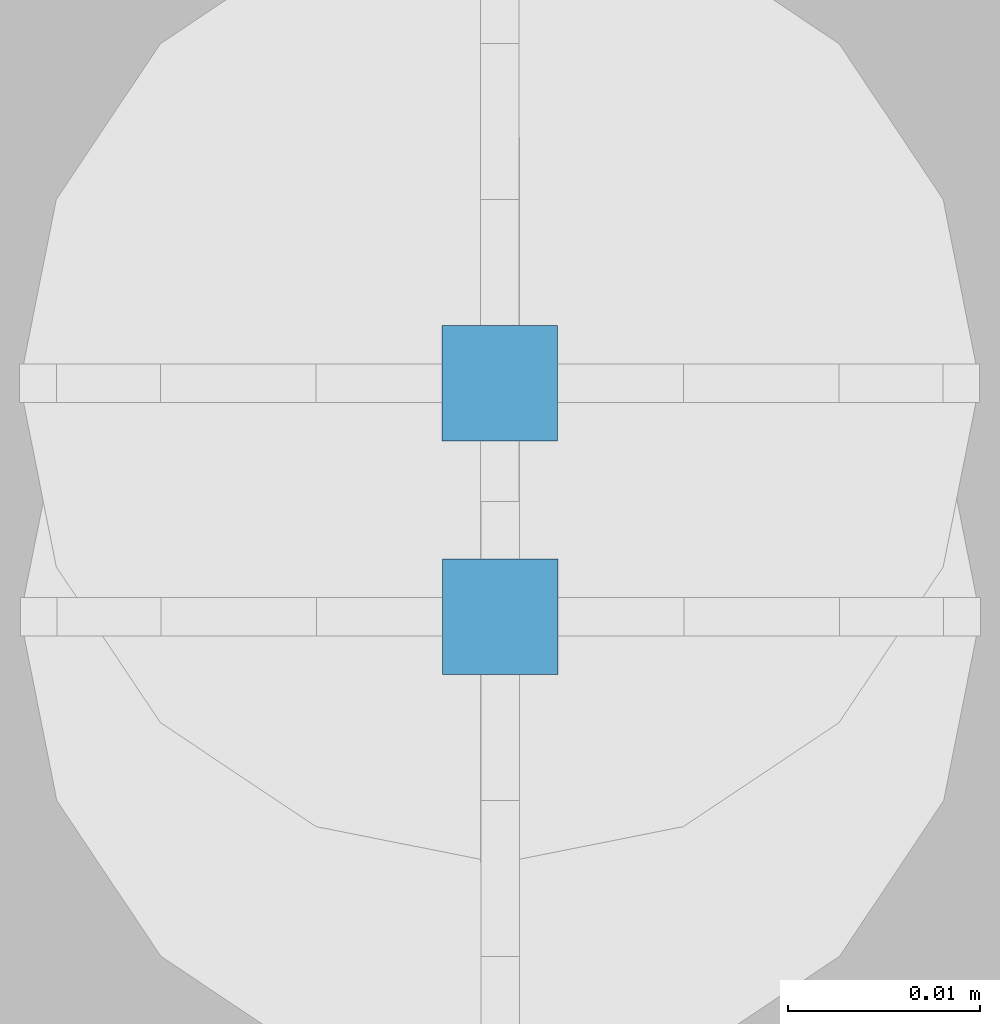
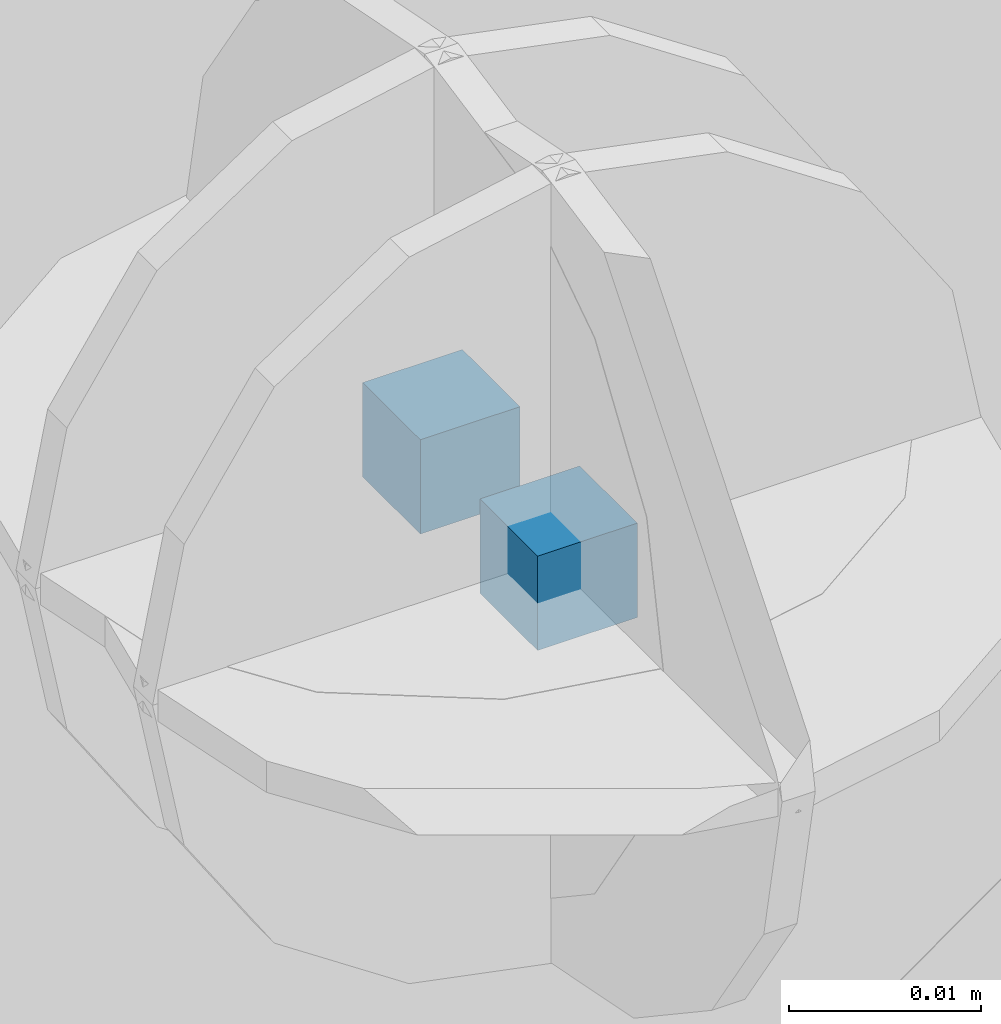
# One storey, part 69 of 325: 2 columns, 3 elements without a shape of their own.
"""IFC2X3 building model written with IfcOpenShell, lengths in millimetres."""

import ifcopenshell
import ifcopenshell.guid

model = None  # the IFC model being written
_history = None  # IfcOwnerHistory: only IFC2X3 demands one
_inside = {}  # id of a spatial element -> (the spatial element, [elements in it])
_under = {}  # id of a project, library or spatial element -> (it, [spatial elements below it])
_declared = {}  # id of a project -> (the project, [libraries it declares])
_typed = {}  # id of a type object -> (the type object, [elements of that type])
_made_of = {}  # id of a material, layer set ... -> (it, [elements and type objects made of it])


def new_model(schema):
    """Start an empty IFC model of exactly this schema.

    Asked for "IFC4X3", IfcOpenShell would pick the latest addendum, in which some entities
    have other attributes; the version numbers below select the first issue.
    IFC2X3 requires an IfcOwnerHistory on every rooted entity: one is made here for all.
    """
    global model, _history
    if schema == "IFC4X3":
        model = ifcopenshell.file(schema_version=(4, 3, 0, 0))
    else:
        model = ifcopenshell.file(schema=schema)
    _inside.clear()
    _under.clear()
    _declared.clear()
    _typed.clear()
    _made_of.clear()
    _history = None
    if model.schema == "IFC2X3":
        org = make("IfcOrganization", Name="unknown")
        user = make(
            "IfcPersonAndOrganization",
            ThePerson=make("IfcPerson", FamilyName="unknown"),
            TheOrganization=org,
        )
        app = make(
            "IfcApplication",
            ApplicationDeveloper=org,
            Version="unknown",
            ApplicationFullName="unknown",
            ApplicationIdentifier="unknown",
        )
        _history = make(
            "IfcOwnerHistory",
            OwningUser=user,
            OwningApplication=app,
            ChangeAction="ADDED",
            CreationDate=0,
        )
    return model


def make(cls, **values):
    """One entity of the class cls with the attributes given. An attribute that is None is left unset."""
    return model.create_entity(
        cls, **{name: value for name, value in values.items() if value is not None}
    )


def rooted(cls, **values):
    """An entity with a GlobalId (a new one), such as an element, a storey or a relation."""
    return make(cls, GlobalId=ifcopenshell.guid.new(), OwnerHistory=_history, **values)


def si_unit(unit_type, name, prefix=None):
    """IfcSIUnit, for example si_unit("LENGTHUNIT", "METRE", prefix="MILLI")."""
    return make("IfcSIUnit", UnitType=unit_type, Prefix=prefix, Name=name)


def assignment(units):
    """IfcUnitAssignment: the units of a project."""
    return None if units is None else make("IfcUnitAssignment", Units=units)


def point(xyz):
    """IfcCartesianPoint."""
    return None if xyz is None else make("IfcCartesianPoint", Coordinates=xyz)


def direction(xyz):
    """IfcDirection."""
    return None if xyz is None else make("IfcDirection", DirectionRatios=xyz)


def frame(location, z_axis=None, x_axis=None):
    """IfcAxis2Placement3D, a coordinate frame: its origin and axes. An axis left out is left unset."""
    return make(
        "IfcAxis2Placement3D",
        Location=point(location),
        Axis=direction(z_axis),
        RefDirection=direction(x_axis),
    )


def origin_with_axes():
    """The frame at (0, 0, 0) with the z axis (0, 0, 1) and the x axis (1, 0, 0) written out."""
    return frame((0.0, 0.0, 0.0), z_axis=(0.0, 0.0, 1.0), x_axis=(1.0, 0.0, 0.0))


def place(relative_to, where):
    """IfcLocalPlacement: puts the frame where relative to a parent placement (None: the world)."""
    return make(
        "IfcLocalPlacement", PlacementRelTo=relative_to, RelativePlacement=where
    )


def context(
    kind, dimensions, precision=None, world=None, true_north=None, identifier=None
):
    """IfcGeometricRepresentationContext, for example the 3D "Model" context."""
    return make(
        "IfcGeometricRepresentationContext",
        ContextIdentifier=identifier,
        ContextType=kind,
        CoordinateSpaceDimension=dimensions,
        Precision=precision,
        WorldCoordinateSystem=world,
        TrueNorth=true_north,
    )


def subcontext(parent, identifier, kind, view, scale=None):
    """IfcGeometricRepresentationSubContext, for example "Body" below "Model"."""
    return make(
        "IfcGeometricRepresentationSubContext",
        ContextIdentifier=identifier,
        ContextType=kind,
        ParentContext=parent,
        TargetScale=scale,
        TargetView=view,
    )


def project(units=None, contexts=None):
    """IfcProject with its units and contexts."""
    return rooted(
        "IfcProject",
        Name="project",
        RepresentationContexts=contexts,
        UnitsInContext=assignment(units),
    )


def spatial(cls, under=None, at=None, **own):
    """A site, building, storey or space (cls), placed at a placement, below another one or the project."""
    s = rooted(cls, ObjectPlacement=at, **own)
    if under is not None:
        _under.setdefault(under.id(), (under, []))[1].append(s)
    return s


def faces_of(points, faces, orient=None, outer=None):
    """IfcFace entities. A face is a list of loops; a loop is a list of indices into points, from 0.

    orient and outer hold one flag for each loop. By default every Orientation is true, the
    first loop of a face is its IfcFaceOuterBound and the others are IfcFaceBound.
    """
    made = []
    for i, loops in enumerate(faces):
        bounds = []
        for j, loop in enumerate(loops):
            is_outer = j == 0 if outer is None else outer[i][j]
            bounds.append(
                make(
                    "IfcFaceOuterBound" if is_outer else "IfcFaceBound",
                    Bound=make("IfcPolyLoop", Polygon=[points[k] for k in loop]),
                    Orientation=True if orient is None else orient[i][j],
                )
            )
        made.append(make("IfcFace", Bounds=bounds))
    return made


def faceted_brep(points, faces, orient=None, outer=None, voids=None):
    """IfcFacetedBrep: a solid bounded by flat faces; with voids (closed shells), ...WithVoids."""
    shared = [point(p) for p in points]
    hull = make("IfcClosedShell", CfsFaces=faces_of(shared, faces, orient, outer))
    if voids is None:
        return make("IfcFacetedBrep", Outer=hull)
    return make(
        "IfcFacetedBrepWithVoids",
        Outer=hull,
        Voids=[
            make(cls, CfsFaces=faces_of(shared, fs, o, b)) for cls, fs, o, b in voids
        ],
    )


def shape(context_of_items, identifier, shape_type, items):
    """IfcShapeRepresentation: the items that make up one representation, for example the "Body"."""
    return make(
        "IfcShapeRepresentation",
        ContextOfItems=context_of_items,
        RepresentationIdentifier=identifier,
        RepresentationType=shape_type,
        Items=items,
    )


def material(Name=None, Category=None):
    """IfcMaterial."""
    return make("IfcMaterial", Name=Name, Category=Category)


def made_of(thing, what):
    """Note that an element or type object is made of a material, layer set ...; save() writes the relation."""
    if what is not None:
        _made_of.setdefault(what.id(), (what, []))[1].append(thing)
    return thing


def type_object(cls, material=None, **own):
    """A type object (cls), such as IfcWallType, which elements share."""
    return made_of(rooted(cls, **own), material)


def element(
    cls,
    number,
    at=None,
    inside=None,
    cuts=None,
    type_object=None,
    material=None,
    context=None,
    identifier="Body",
    shape_type=None,
    held_by="IfcProductDefinitionShape",
    body=None,
    shapes=None,
    **own,
):
    """One element of the class cls, such as IfcWall. Its Tag is "e" and its number.

    at: its placement. inside: the storey or other place that contains it. cuts: it is an
    opening in that element (IfcRelVoidsElement). A single representation is given by context,
    identifier, shape_type and body (its items); several are given by shapes. held_by: the class
    of the entity that holds the representations. save() writes the other relations.
    """
    e = rooted(cls, Tag="e%d" % number, ObjectPlacement=at, **own)
    if body is not None:
        shapes = [shape(context, identifier, shape_type, body)]
    if shapes is not None:
        e.Representation = make(held_by, Representations=shapes)
    if inside is not None:
        _inside.setdefault(inside.id(), (inside, []))[1].append(e)
    if cuts is not None:
        rooted(
            "IfcRelVoidsElement", RelatingBuildingElement=cuts, RelatedOpeningElement=e
        )
    if type_object is not None:
        _typed.setdefault(type_object.id(), (type_object, []))[1].append(e)
    return made_of(e, material)


def aggregate(whole, parts):
    """IfcRelAggregates: a whole, such as a stair, and the parts it consists of."""
    return rooted("IfcRelAggregates", RelatingObject=whole, RelatedObjects=parts)


def save(model, path):
    """Write the relations noted so far, then the file.

    IfcRelAggregates (storeys below a building ...), IfcRelContainedInSpatialStructure (elements
    in a storey), IfcRelDefinesByType, IfcRelAssociatesMaterial and IfcRelDeclares: one each for
    every whole, place, type object, material and project.
    """
    for whole, parts in _under.values():
        aggregate(whole, parts)
    for where, things in _inside.values():
        rooted(
            "IfcRelContainedInSpatialStructure",
            RelatedElements=things,
            RelatingStructure=where,
        )
    for kind, things in _typed.values():
        rooted("IfcRelDefinesByType", RelatedObjects=things, RelatingType=kind)
    for what, things in _made_of.values():
        rooted("IfcRelAssociatesMaterial", RelatedObjects=things, RelatingMaterial=what)
    for by, libraries in _declared.values():
        rooted("IfcRelDeclares", RelatingContext=by, RelatedDefinitions=libraries)
    model.write(path)


model = new_model("IFC2X3")

# Units and contexts
model_context = context("Model", 3, precision=1e-05, world=origin_with_axes())
body_context = subcontext(model_context, "Body", "Model", "MODEL_VIEW")
ifc_project = project(units=[si_unit("LENGTHUNIT", "METRE", prefix="MILLI"), si_unit("AREAUNIT", "SQUARE_METRE"), si_unit("VOLUMEUNIT", "CUBIC_METRE"), si_unit("MASSUNIT", "GRAM", prefix="KILO"), si_unit("TIMEUNIT", "SECOND"), si_unit("PLANEANGLEUNIT", "RADIAN"), si_unit("SOLIDANGLEUNIT", "STERADIAN"), si_unit("THERMODYNAMICTEMPERATUREUNIT", "DEGREE_CELSIUS"), si_unit("LUMINOUSINTENSITYUNIT", "LUMEN")], contexts=[model_context])

# Site, building, storey
site_placement = place(None, origin_with_axes())
site = spatial("IfcSite", under=ifc_project, at=site_placement, CompositionType="ELEMENT")
building_placement = place(site_placement, origin_with_axes())
building = spatial("IfcBuilding", under=site, at=building_placement, CompositionType="ELEMENT")
storey_placement = place(building_placement, origin_with_axes())
storey = spatial("IfcBuildingStorey", under=building, at=storey_placement, Name="1", CompositionType="ELEMENT", Elevation=0.0)

# Assemblies, columns
assembly_1_placement = place(storey_placement, origin_with_axes())
assembly_1 = element("IfcElementAssembly", 1, at=assembly_1_placement, inside=storey, AssemblyPlace="NOTDEFINED", PredefinedType="REINFORCEMENT_UNIT")
assembly_2_placement = place(assembly_1_placement, origin_with_axes())
assembly_2 = element("IfcElementAssembly", 2, at=assembly_2_placement, Name="Steel Assembly", AssemblyPlace="NOTDEFINED", PredefinedType="RIGID_FRAME")
ifc_material = material(Name="STEEL/Steel_Undefined")
column_type = type_object("IfcColumnType", PredefinedType="NOTDEFINED")
column_1_placement = place(assembly_2_placement, frame((18614.0217877251, 20625.7600508513, 83872.854035961), z_axis=(0.0, -1.0, 0.0), x_axis=(0.0, 0.0, 1.0)))
column_1 = element("IfcColumn", 3, at=column_1_placement, type_object=column_type, material=ifc_material, Name="PP", context=body_context, shape_type="Brep", body=[
    faceted_brep([(0.0, 3.0, -3.0), (0.0, 2.99999999999636, 3.0), (6.0, 2.99999999999636, 3.0), (6.0, 3.0, -3.0), (0.0, -3.00000000000364, 3.0), (6.0, -3.00000000000364, 3.0), (0.0, -3.0, -3.0), (6.0, -3.0, -3.0)], [[[0, 1, 2, 3]], [[1, 4, 5, 2]], [[4, 6, 7, 5]], [[6, 0, 3, 7]], [[5, 7, 3, 2]], [[6, 4, 1, 0]]]),
])
aggregate(assembly_2, [column_1])
assembly_3_placement = place(assembly_1_placement, origin_with_axes())
assembly_3 = element("IfcElementAssembly", 4, at=assembly_3_placement, Name="Steel Assembly", AssemblyPlace="NOTDEFINED", PredefinedType="RIGID_FRAME")
aggregate(assembly_1, [assembly_2, assembly_3])
column_2_placement = place(assembly_3_placement, frame((18614.0488800542, 20613.5887932168, 83872.8235861413), z_axis=(0.0, -1.0, 0.0), x_axis=(0.0, 0.0, 1.0)))
column_2 = element("IfcColumn", 5, at=column_2_placement, type_object=column_type, material=ifc_material, Name="PP", context=body_context, shape_type="Brep", body=[
    faceted_brep([(0.0, 3.0, -3.0), (0.0, 2.99999999999636, 3.0), (6.0, 2.99999999999636, 3.0), (6.0, 3.0, -3.0), (0.0, -3.00000000000364, 3.0), (6.0, -3.00000000000364, 3.0), (0.0, -3.0, -3.0), (6.0, -3.0, -3.0)], [[[0, 1, 2, 3]], [[1, 4, 5, 2]], [[4, 6, 7, 5]], [[6, 0, 3, 7]], [[5, 7, 3, 2]], [[6, 4, 1, 0]]]),
])
aggregate(assembly_3, [column_2])

save(model, "model.ifc")
